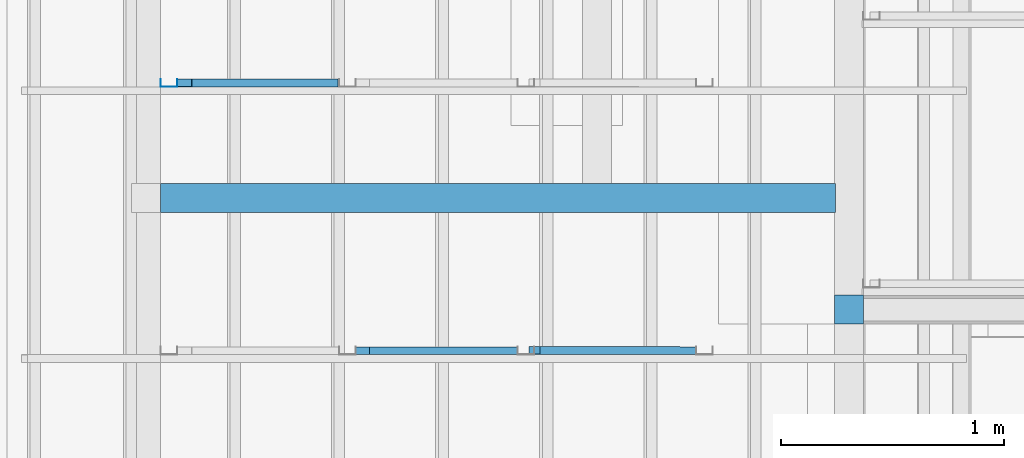
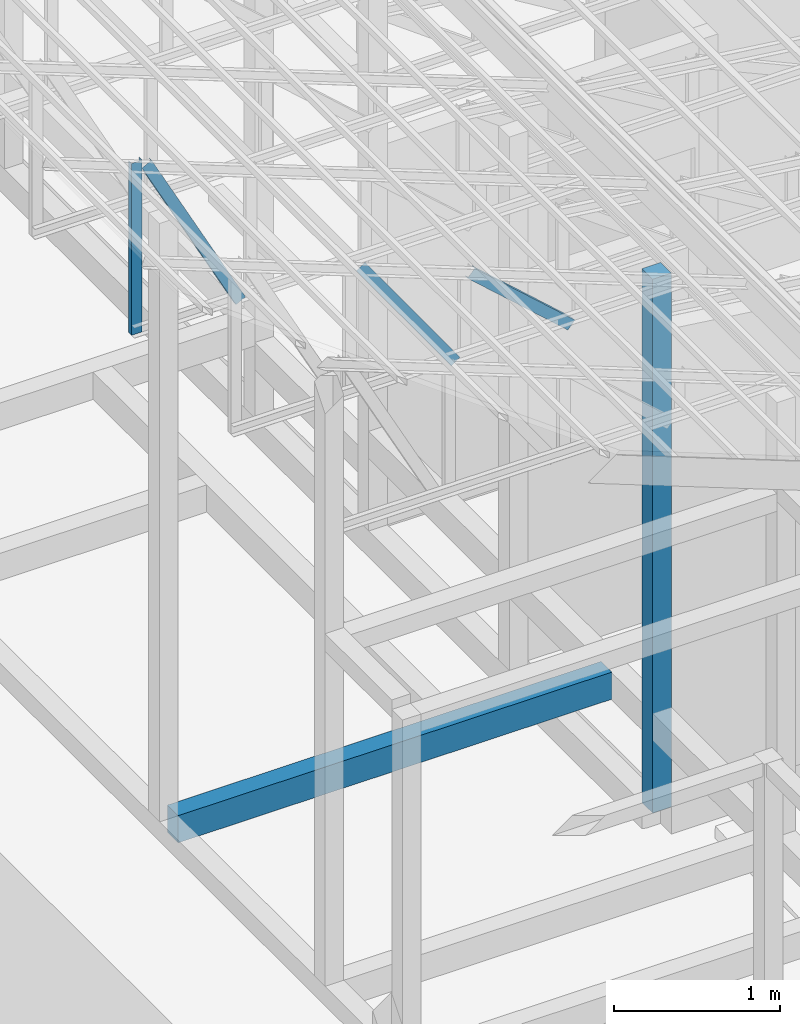
# One storey, part 4 of 22: 4 members, 2 beams, 1 element without a shape of its own.
"""IFC4 building model written with IfcOpenShell, lengths in millimetres."""

from ifc_helpers import new_model, entity, si_unit, converted_unit, frame, origin_with_axes, origin_2d_with_axis, place, context, subcontext, project, spatial, indexed_curve, rectangle, c_section, outline, extrude, material, material_profile, profile_set, profile_usage, type_object, element, aggregate, save


model = new_model("IFC4")

# Units and contexts
model_context = context("Model", 3, precision=1e-05, world=origin_with_axes())
plan_context = context("Plan", 2, precision=1e-05, world=origin_2d_with_axis())
body_context = subcontext(model_context, "Body", "Model", "MODEL_VIEW")
ifc_project = project(units=[si_unit("VOLUMEUNIT", "CUBIC_METRE"), si_unit("LENGTHUNIT", "METRE", prefix="MILLI"), si_unit("AREAUNIT", "SQUARE_METRE"), converted_unit("PLANEANGLEUNIT", "degree", entity("IfcReal", 0.0174532925199433), si_unit("PLANEANGLEUNIT", "RADIAN"), dimensions=[0, 0, 0, 0, 0, 0, 0])], contexts=[model_context, plan_context])

# Site, building, storey
site_placement = place(None, origin_with_axes())
site = spatial("IfcSite", under=ifc_project, at=site_placement)
building_placement = place(site_placement, origin_with_axes())
building = spatial("IfcBuilding", under=site, at=building_placement, Name="2")
storey_placement = place(building_placement, frame((0.0, 0.0, 200.000002980232), z_axis=(0.0, 0.0, 1.0), x_axis=(1.0, 0.0, 0.0)))
storey = spatial("IfcBuildingStorey", under=building, at=storey_placement)

# Beams
ifc_material_1 = material(Name="Concrete")
ifc_material_profile_1 = material_profile(ifc_material_1, outline(indexed_curve([(-65.0, 99.9999923706055), (65.0, 99.9999923706055), (65.0, -99.9999923706055), (-65.0, -99.9999923706055), (-65.0, 99.9999923706055)])))
ifc_profile_set_1 = profile_set([ifc_material_profile_1])
ifc_profile_usage_1 = profile_usage(ifc_profile_set_1, cardinal=2)
beam_type_1 = type_object("IfcBeamType", PredefinedType="BEAM", material=ifc_profile_set_1)
beam_1_placement = place(storey_placement, frame((-7084.99813079834, 7000.00047683716, 535.000070929528), z_axis=(0.999999999999932, -1.9470714107682e-07, 3.13916473260157e-07), x_axis=(1.94707183709391e-07, 0.99999999999997, -1.49011611938472e-07)))
element("IfcBeam", 1, at=beam_1_placement, inside=storey, type_object=beam_type_1, material=ifc_profile_usage_1, Name="Beam", PredefinedType="BEAM", context=body_context, shape_type="SweptSolid", body=[
    extrude(outline(indexed_curve([(-65.0, 99.9999923706055), (65.0, 99.9999923706055), (65.0, -99.9999923706055), (-65.0, -99.9999923706055), (-65.0, 99.9999923706055)])), frame((0.0, 100.0, 0.0), z_axis=(0.0, 0.0, 1.0), x_axis=(1.0, 0.0, 0.0)), (0.0, 0.0, 1.0), 3025.44452774385),
])
ifc_material_profile_2 = material_profile(ifc_material_1, rectangle(XDim=130.000015258789, YDim=130.000015258789, kind="CURVE"))
ifc_profile_set_2 = profile_set([ifc_material_profile_2])
ifc_profile_usage_2 = profile_usage(ifc_profile_set_2, cardinal=5)
beam_type_2 = type_object("IfcBeamType", PredefinedType="BEAM", material=ifc_profile_set_2)
beam_2_placement = place(storey_placement, frame((-3999.99761581421, 6500.0, -1.49011609718031e-05), z_axis=(0.0, 0.0, 1.0), x_axis=(1.0, 0.0, 0.0)))
element("IfcBeam", 2, at=beam_2_placement, inside=storey, type_object=beam_type_2, material=ifc_profile_usage_2, Name="Column", PredefinedType="BEAM", context=body_context, shape_type="SweptSolid", body=[
    extrude(rectangle(XDim=130.000015258789, YDim=130.000015258789, kind="CURVE"), origin_with_axes(), (0.0, 0.0, 1.0), 3934.94913943236),
])

# Assembly, members
assembly_placement = place(storey_placement, frame((-3938.51041793823, 5099.00283813477, 3935.3459328413), z_axis=(0.0, 0.0, 1.0), x_axis=(1.0, 0.0, 0.0)))
assembly = element("IfcElementAssembly", 3, at=assembly_placement, inside=storey, Name="2")
ifc_material_2 = material(Name="STEEL")
ifc_material_profile_3 = material_profile(ifc_material_2, c_section(Depth=75.0, Width=35.0, WallThickness=1.0, Girth=1.0, kind="CURVE"))
ifc_profile_set_3 = profile_set([ifc_material_profile_3])
ifc_profile_usage_3 = profile_usage(ifc_profile_set_3, cardinal=7)
member_type = type_object("IfcMemberType", Name="C75", PredefinedType="CHORD", material=ifc_profile_set_3)
member_1_placement = place(assembly_placement, frame((-1445.26290893555, 1235.96096038818, 624.074935913086), z_axis=(0.745142107017777, -0.00102660805644996, -0.66690493057482), x_axis=(0.00137753843534741, 0.999999051193456, -2.17762747561669e-07)))
member_1 = element("IfcMember", 4, at=member_1_placement, type_object=member_type, material=ifc_profile_usage_3, Name="Member", context=body_context, shape_type="SweptSolid", body=[
    extrude(c_section(Depth=75.0, Width=35.0, WallThickness=1.0, Girth=1.0, kind="CURVE"), frame((-17.5, -37.5, 0.0), z_axis=(0.0, 0.0, 1.0), x_axis=(1.0, 0.0, 0.0)), (0.0, 0.0, 1.0), 937.808496265298),
])
ifc_profile_usage_4 = profile_usage(ifc_profile_set_3, cardinal=3)
member_2_placement = place(assembly_placement, frame((-2271.51107788086, 1199.99980926514, 894.618034362793), z_axis=(0.578723368640778, -7.49756619914683e-07, -0.815523919078103), x_axis=(1.02917226740772e-06, 0.999999999999453, -1.89020340712783e-07)))
member_2 = element("IfcMember", 5, at=member_2_placement, type_object=member_type, material=ifc_profile_usage_4, Name="Member", context=body_context, shape_type="SweptSolid", body=[
    extrude(c_section(Depth=75.0, Width=35.0, WallThickness=1.0, Girth=1.0, kind="CURVE"), frame((17.5, 37.5, 0.0), z_axis=(0.0, 0.0, 1.0), x_axis=(1.0, 0.0, 0.0)), (0.0, 0.0, 1.0), 1142.30360336039),
])
ifc_profile_usage_5 = profile_usage(ifc_profile_set_3, cardinal=1)
member_3_placement = place(assembly_placement, frame((-3146.51107788086, 2434.99851226807, 1265.15865325928), z_axis=(-8.74227410463377e-08, -1.50995830949794e-07, -0.999999999999985), x_axis=(-3.13916473260159e-07, 0.999999999999939, -1.50995802528077e-07)))
member_3 = element("IfcMember", 6, at=member_3_placement, type_object=member_type, material=ifc_profile_usage_5, Name="Member", context=body_context, shape_type="SweptSolid", body=[
    extrude(c_section(Depth=75.0, Width=35.0, WallThickness=1.0, Girth=1.0, kind="CURVE"), frame((-17.5, 37.5, 0.0), z_axis=(0.0, 0.0, 1.0), x_axis=(1.0, 0.0, 0.0)), (0.0, 0.0, 1.0), 1266.51238309135),
])
ifc_profile_usage_6 = profile_usage(ifc_profile_set_3, cardinal=9)
member_4_placement = place(assembly_placement, frame((-3006.42156600952, 2399.99866485596, 1241.45650863647), z_axis=(0.468464370953309, -3.43728484817469e-07, -0.88348238983423), x_axis=(6.7154434191237e-07, 0.999999999999774, -3.29761675743537e-08)))
member_4 = element("IfcMember", 7, at=member_4_placement, type_object=member_type, material=ifc_profile_usage_6, Name="Member", context=body_context, shape_type="SweptSolid", body=[
    extrude(c_section(Depth=75.0, Width=35.0, WallThickness=1.0, Girth=1.0, kind="CURVE"), frame((17.5, -37.5, 0.0), z_axis=(0.0, 0.0, 1.0), x_axis=(1.0, 0.0, 0.0)), (0.0, 0.0, 1.0), 1399.63894386164),
])
aggregate(assembly, [member_1, member_2, member_3, member_4])

save(model, "model.ifc")
